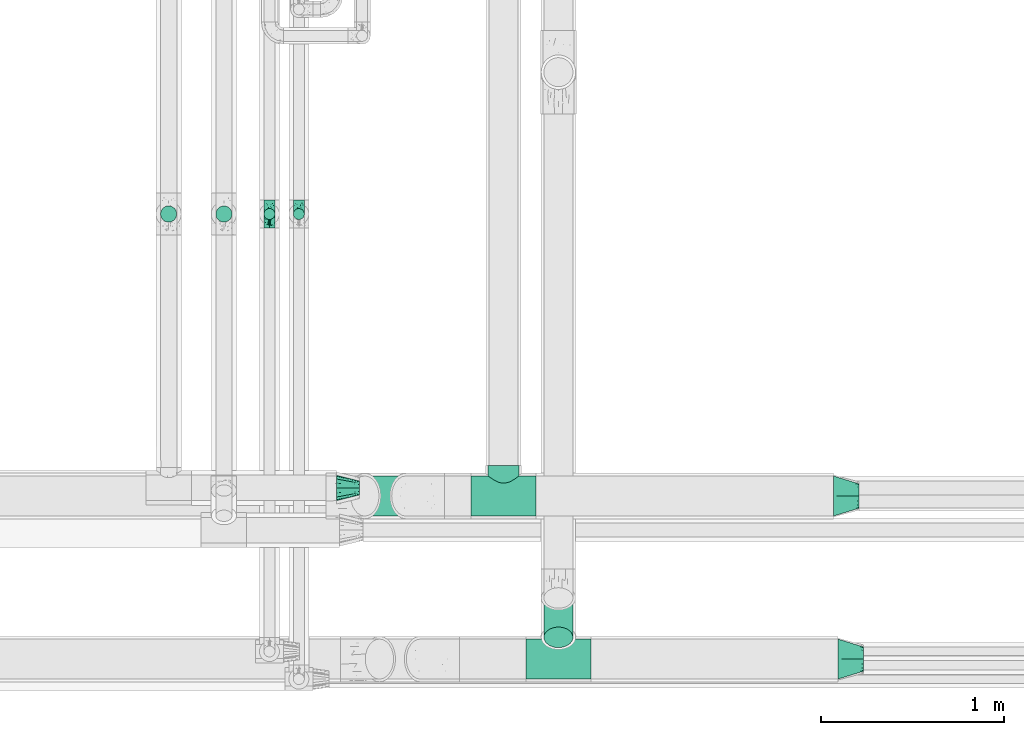
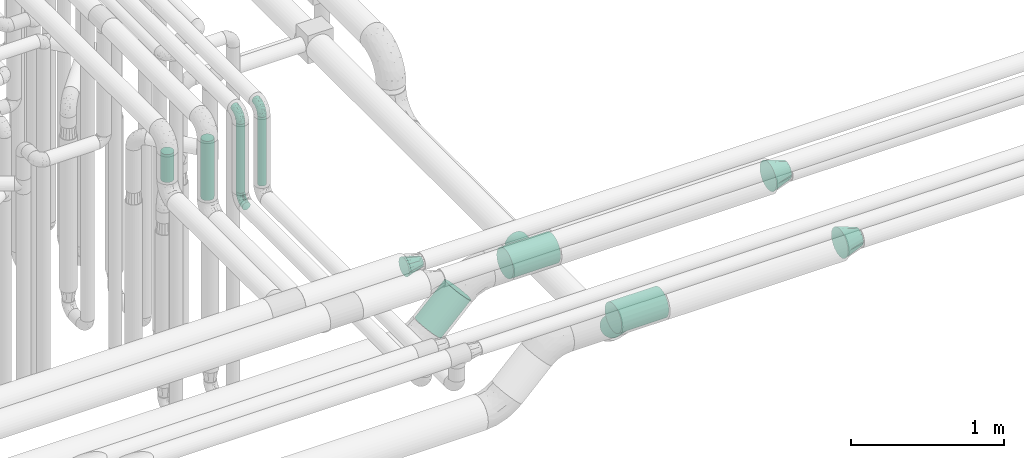
# One storey, part 605 of 827: 8 flow fittings, 6 flow segments.
"""IFC2X3 building model written with IfcOpenShell, lengths in millimetres."""

from ifc_helpers import new_model, entity, si_unit, converted_unit, derived_unit, direction, frame, origin, origin_2d_with_axis, place, context, subcontext, project, spatial, circle, extrude, faceted_brep, source, transform, mapped, material, type_object, type_shapes, element, save


model = new_model("IFC2X3")

# Units and contexts
model_context = context("Model", 3, precision=0.01, world=origin(), true_north=direction((6.12303176911189e-17, 1.0)))
body_context = subcontext(model_context, "Body", "Model", "MODEL_VIEW")
ifc_project = project(units=[si_unit("LENGTHUNIT", "METRE", prefix="MILLI"), si_unit("AREAUNIT", "SQUARE_METRE"), si_unit("VOLUMEUNIT", "CUBIC_METRE"), converted_unit("PLANEANGLEUNIT", "DEGREE", entity("IfcRatioMeasure", 0.0174532925199433), si_unit("PLANEANGLEUNIT", "RADIAN"), dimensions=[0, 0, 0, 0, 0, 0, 0]), si_unit("MASSUNIT", "GRAM", prefix="KILO"), derived_unit("MASSDENSITYUNIT", [(si_unit("MASSUNIT", "GRAM", prefix="KILO"), 1), (si_unit("LENGTHUNIT", "METRE"), -3)]), derived_unit("MOMENTOFINERTIAUNIT", [(si_unit("LENGTHUNIT", "METRE"), 4)]), si_unit("TIMEUNIT", "SECOND"), si_unit("FREQUENCYUNIT", "HERTZ"), si_unit("THERMODYNAMICTEMPERATUREUNIT", "DEGREE_CELSIUS"), derived_unit("THERMALTRANSMITTANCEUNIT", [(si_unit("MASSUNIT", "GRAM", prefix="KILO"), 1), (si_unit("THERMODYNAMICTEMPERATUREUNIT", "KELVIN"), -1), (si_unit("TIMEUNIT", "SECOND"), -3)]), derived_unit("VOLUMETRICFLOWRATEUNIT", [(si_unit("LENGTHUNIT", "METRE"), 3), (si_unit("TIMEUNIT", "SECOND"), -1)]), derived_unit("MASSFLOWRATEUNIT", [(si_unit("MASSUNIT", "GRAM", prefix="KILO"), 1), (si_unit("TIMEUNIT", "SECOND"), -1)]), derived_unit("ROTATIONALFREQUENCYUNIT", [(si_unit("TIMEUNIT", "SECOND"), -1)]), si_unit("ELECTRICCURRENTUNIT", "AMPERE"), si_unit("ELECTRICVOLTAGEUNIT", "VOLT"), si_unit("POWERUNIT", "WATT"), si_unit("FORCEUNIT", "NEWTON", prefix="KILO"), si_unit("ILLUMINANCEUNIT", "LUX"), si_unit("LUMINOUSFLUXUNIT", "LUMEN"), si_unit("LUMINOUSINTENSITYUNIT", "CANDELA"), derived_unit("USERDEFINED", [(si_unit("MASSUNIT", "GRAM", prefix="KILO"), -1), (si_unit("LENGTHUNIT", "METRE"), -2), (si_unit("TIMEUNIT", "SECOND"), 3), (si_unit("LUMINOUSFLUXUNIT", "LUMEN"), 1)]), derived_unit("LINEARVELOCITYUNIT", [(si_unit("LENGTHUNIT", "METRE"), 1), (si_unit("TIMEUNIT", "SECOND"), -1)]), si_unit("PRESSUREUNIT", "PASCAL"), derived_unit("USERDEFINED", [(si_unit("LENGTHUNIT", "METRE"), -2), (si_unit("MASSUNIT", "GRAM", prefix="KILO"), 1), (si_unit("TIMEUNIT", "SECOND"), -2)]), derived_unit("LINEARFORCEUNIT", [(si_unit("MASSUNIT", "GRAM", prefix="KILO"), 1), (si_unit("LENGTHUNIT", "METRE"), 1), (si_unit("TIMEUNIT", "SECOND"), -2), (si_unit("LENGTHUNIT", "METRE"), -1)]), derived_unit("PLANARFORCEUNIT", [(si_unit("MASSUNIT", "GRAM", prefix="KILO"), 1), (si_unit("LENGTHUNIT", "METRE"), 1), (si_unit("TIMEUNIT", "SECOND"), -2), (si_unit("LENGTHUNIT", "METRE"), -2)])], contexts=[model_context])

# Site, building, storey
site_placement = place(None, origin())
site = spatial("IfcSite", under=ifc_project, at=site_placement, CompositionType="ELEMENT")
building_placement = place(site_placement, origin())
building = spatial("IfcBuilding", under=site, at=building_placement, CompositionType="ELEMENT")
storey_placement = place(building_placement, frame((0.0, 0.0, 28200.0)))
storey = spatial("IfcBuildingStorey", under=building, at=storey_placement, Name="08", CompositionType="ELEMENT", Elevation=28200.0)

# Flow segments
pipe_segment_type_1 = type_object("IfcPipeSegmentType", PredefinedType="NOTDEFINED")
flow_segment_1_placement = place(storey_placement, frame((36911.29, 7155.11, 2508.8)))
element("IfcFlowSegment", 1, at=flow_segment_1_placement, inside=storey, type_object=pipe_segment_type_1, context=body_context, shape_type="SweptSolid", body=[
    extrude(circle(Radius=109.5, at=origin_2d_with_axis()), frame((79.02, 111.1, 79.03), z_axis=(0.707128324867819, 0.0, 0.707085236848877), x_axis=(0.0, 1.0, 0.0)), (0.0, 0.0, 1.0), 317.064992744885),
])
flow_segment_2_placement = place(storey_placement, frame((37967.2, 6435.98, 2508.09)))
element("IfcFlowSegment", 2, at=flow_segment_2_placement, inside=storey, type_object=pipe_segment_type_1, context=body_context, shape_type="SweptSolid", body=[
    extrude(circle(Radius=79.5, at=origin_2d_with_axis()), frame((81.1, 57.81, 273.12), z_axis=(0.0, 0.707106781186546, -0.707106781186549), x_axis=(1.0, 0.0, 0.0)), (0.0, 0.0, 1.0), 304.487373415324),
])
pipe_segment_type_2 = type_object("IfcPipeSegmentType", PredefinedType="NOTDEFINED")
flow_segment_3_placement = place(storey_placement, frame((36174.19, 8761.54, 2964.0)))
element("IfcFlowSegment", 3, at=flow_segment_3_placement, inside=storey, type_object=pipe_segment_type_2, context=body_context, shape_type="SweptSolid", body=[
    extrude(circle(Radius=44.25, at=origin_2d_with_axis()), frame((45.85, 45.85, 0.0), z_axis=(0.0, 0.0, 1.0), x_axis=(-1.0, 0.0, 0.0)), (0.0, 0.0, 1.0), 472.000402937329),
])
flow_segment_4_placement = place(storey_placement, frame((35872.22, 8761.54, 3214.0)))
element("IfcFlowSegment", 4, at=flow_segment_4_placement, inside=storey, type_object=pipe_segment_type_2, context=body_context, shape_type="SweptSolid", body=[
    extrude(circle(Radius=44.25, at=origin_2d_with_axis()), frame((45.85, 45.85, 0.0)), (0.0, 0.0, 1.0), 222.001032735806),
])
flow_segment_5_placement = place(storey_placement, frame((36598.05, 8775.79, 2926.0)))
element("IfcFlowSegment", 5, at=flow_segment_5_placement, inside=storey, type_object=pipe_segment_type_2, context=body_context, shape_type="SweptSolid", body=[
    extrude(circle(Radius=30.0, at=origin_2d_with_axis()), frame((31.6, 31.6, 0.0)), (0.0, 0.0, 1.0), 547.999328702734),
])
flow_segment_6_placement = place(storey_placement, frame((36437.12, 8775.79, 2926.0)))
element("IfcFlowSegment", 6, at=flow_segment_6_placement, inside=storey, type_object=pipe_segment_type_2, context=body_context, shape_type="SweptSolid", body=[
    extrude(circle(Radius=30.0, at=origin_2d_with_axis()), frame((31.6, 31.6, 0.0), z_axis=(0.0, 0.0, 1.0), x_axis=(-1.0, 0.0, 0.0)), (0.0, 0.0, 1.0), 548.000000000049),
])

# Flow fittings
ifc_material = material()
pipe_fitting_type_1 = type_object("IfcPipeFittingType", Name="ADSK_1", PredefinedType="NOTDEFINED", material=ifc_material)
shared_shape_1 = source(origin(), body_context, "Body", "Brep", [
    faceted_brep([(-76.0, 15.07, -26.11), (-76.0, 7.8, -29.12), (-76.0, 0.0, -30.15), (-76.0, -7.8, -29.12), (-76.0, -15.08, -26.11), (-76.0, -21.32, -21.32), (-76.0, -26.11, -15.08), (-76.0, -29.12, -7.8), (-76.0, -30.15, 0.0), (-76.0, -29.12, 7.8), (-76.0, -26.11, 15.07), (-76.0, -21.32, 21.32), (-76.0, -15.08, 26.11), (-76.0, -7.8, 29.12), (-76.0, 0.0, 30.15), (-76.0, 7.8, 29.12), (-76.0, 15.07, 26.11), (-76.0, 21.32, 21.32), (-76.0, 26.11, 15.07), (-76.0, 29.12, 7.8), (-76.0, 30.15, 0.0), (-76.0, 29.12, -7.8), (-76.0, 26.11, -15.08), (-76.0, 21.32, -21.32), (0.0, 76.0, -30.15), (-7.8, 76.0, -29.12), (-15.07, 76.0, -26.11), (-21.32, 76.0, -21.32), (-26.11, 76.0, -15.08), (-29.12, 76.0, -7.8), (-30.15, 76.0, 0.0), (-29.12, 76.0, 7.8), (-26.11, 76.0, 15.07), (-21.32, 76.0, 21.32), (-15.07, 76.0, 26.11), (-7.8, 76.0, 29.12), (0.0, 76.0, 30.15), (7.8, 76.0, 29.12), (15.08, 76.0, 26.11), (21.32, 76.0, 21.32), (26.11, 76.0, 15.07), (29.12, 76.0, 7.8), (30.15, 76.0, 0.0), (29.12, 76.0, -7.8), (26.11, 76.0, -15.08), (21.32, 76.0, -21.32), (15.08, 76.0, -26.11), (7.8, 76.0, -29.12), (10.79, 31.43, 21.07), (4.32, 31.7, 25.72), (1.65, 15.19, 19.92), (-61.17, -27.8, 0.0), (-51.1, -25.49, 9.84), (-56.14, -10.61, 27.27), (-31.7, -4.32, 25.72), (-39.75, 1.72, 29.41), (-43.2, -24.95, 0.0), (-1.86, 1.86, 0.0), (4.49, 7.65, 5.78), (-7.82, -4.61, 5.83), (-56.21, -22.79, 17.21), (-58.98, -3.38, 29.7), (-53.96, 5.6, 30.07), (-10.86, 10.86, 25.48), (-17.2, -2.6, 20.44), (-49.15, -16.01, 22.7), (-22.18, -14.24, 7.99), (-28.4, -17.42, 0.0), (-13.61, -9.88, 0.0), (-39.0, 23.48, 27.76), (-58.76, 12.54, 28.36), (-41.61, 15.41, 29.48), (16.01, 49.15, 22.7), (-58.55, 25.93, 19.53), (-51.53, 33.5, 13.51), (-64.92, 28.76, 12.4), (-7.48, 23.14, 28.25), (-1.72, 39.75, 29.41), (-12.04, 27.88, 29.88), (-63.91, 18.81, 24.52), (-11.63, 65.16, 28.18), (-4.97, 57.02, 30.05), (9.88, 13.61, 0.0), (-62.5, 31.74, 5.02), (-45.17, 30.98, 21.2), (-21.78, 9.76, 28.58), (10.61, 56.14, 27.27), (-32.09, 54.42, 13.26), (22.79, 56.21, 17.21), (15.38, 31.17, 15.63), (25.49, 51.1, 9.84), (21.84, 36.35, 5.92), (24.95, 43.2, 0.0), (3.38, 58.98, 29.7), (-31.17, -15.38, 15.63), (-39.39, 41.78, 15.45), (-34.56, 41.13, 20.79), (-39.81, -23.25, 5.49), (27.8, 61.17, 0.0), (-31.74, 62.5, 5.02), (-53.07, 36.29, 0.0), (-42.95, 42.95, 7.29), (-36.29, 53.07, 0.0), (-19.83, 58.51, 24.79), (-25.48, 60.2, 19.41), (-14.53, 50.96, 28.57), (-13.31, 37.09, 30.07), (-26.16, 40.06, 26.4), (-32.43, -10.35, 21.9), (17.42, 28.4, 0.0), (14.24, 22.18, 7.99), (-38.67, 9.72, 30.15), (-24.66, 17.36, 30.09), (-37.08, 31.49, 24.99), (-49.27, 22.83, 25.24), (-20.8, 38.81, 28.63), (-27.58, 27.58, 29.2), (-36.07, -20.23, 10.71), (-15.19, -6.16, 14.9), (6.6, 15.4, 14.49), (-2.51, 2.51, 11.35), (-65.16, 11.63, -28.18), (-49.15, -16.01, -22.7), (-57.02, 4.97, -30.05), (-25.93, 58.55, -19.53), (-33.5, 51.53, -13.51), (-28.76, 64.92, -12.4), (-60.2, 25.48, -19.41), (-58.51, 19.83, -24.79), (4.61, 7.82, -5.83), (-7.65, -4.49, -5.78), (-2.51, 2.51, -11.35), (-62.5, 31.74, -5.02), (-50.96, 14.53, -28.57), (-37.09, 13.31, -30.07), (-42.95, 42.95, -7.29), (25.49, 51.1, -9.84), (22.79, 56.21, -17.21), (-40.06, 26.16, -26.4), (3.38, 58.98, -29.7), (-5.6, 53.96, -30.07), (-27.88, 12.04, -29.88), (-9.76, 21.78, -28.58), (-23.14, 7.48, -28.25), (-51.1, -25.49, -9.84), (15.38, 31.17, -15.63), (16.01, 49.15, -22.7), (-23.48, 39.0, -27.76), (-12.54, 58.76, -28.36), (-15.41, 41.61, -29.48), (-56.21, -22.79, -17.21), (-9.72, 38.67, -30.15), (-17.36, 24.66, -30.09), (-22.18, -14.24, -7.99), (-41.13, 34.56, -20.79), (-31.74, 62.5, -5.02), (-58.98, -3.38, -29.7), (-31.17, -15.38, -15.63), (-56.14, -10.61, -27.27), (14.24, 22.18, -7.99), (23.25, 39.81, -5.49), (-31.49, 37.08, -24.99), (-15.19, -6.16, -14.9), (1.65, 15.19, -19.92), (-18.81, 63.91, -24.52), (-32.59, -11.62, -20.84), (-31.7, -4.32, -25.72), (-17.2, -2.6, -20.44), (-39.75, 1.72, -29.41), (-54.42, 32.09, -13.26), (-30.98, 45.17, -21.2), (10.61, 56.14, -27.27), (10.23, 31.31, -21.52), (4.32, 31.7, -25.72), (-41.78, 39.39, -15.45), (-1.72, 39.75, -29.41), (-36.35, -21.84, -5.92), (-22.83, 49.27, -25.24), (-38.81, 20.8, -28.63), (-27.58, 27.58, -29.2), (-10.86, 10.86, -25.48), (20.23, 36.07, -10.71), (6.6, 15.4, -14.49)], [[[0, 1, 2, 3, 4, 5, 6, 7, 8, 9, 10, 11, 12, 13, 14, 15, 16, 17, 18, 19, 20, 21, 22, 23]], [[24, 25, 26, 27, 28, 29, 30, 31, 32, 33, 34, 35, 36, 37, 38, 39, 40, 41, 42, 43, 44, 45, 46, 47]], [[48, 49, 50]], [[51, 52, 9]], [[53, 54, 55]], [[9, 52, 10]], [[56, 52, 51]], [[57, 58, 59]], [[11, 10, 60]], [[14, 61, 62]], [[63, 54, 64]], [[65, 12, 11]], [[65, 53, 12]], [[66, 67, 68]], [[69, 70, 71]], [[72, 39, 38]], [[73, 74, 75]], [[15, 70, 16]], [[76, 77, 78]], [[16, 79, 17]], [[13, 61, 14]], [[35, 80, 81]], [[14, 62, 15]], [[17, 73, 18]], [[57, 82, 58]], [[20, 19, 83]], [[75, 19, 18]], [[70, 15, 62]], [[73, 84, 74]], [[78, 85, 76]], [[38, 86, 72]], [[32, 31, 87]], [[88, 89, 90]], [[91, 92, 90]], [[72, 86, 49]], [[36, 93, 37]], [[75, 83, 19]], [[36, 35, 81]], [[60, 94, 65]], [[40, 90, 41]], [[95, 96, 87]], [[88, 90, 40]], [[66, 97, 67]], [[90, 98, 41]], [[40, 39, 88]], [[99, 31, 30]], [[20, 83, 100]], [[101, 102, 100]], [[52, 60, 10]], [[102, 99, 30]], [[96, 103, 104]], [[83, 101, 100]], [[12, 53, 13]], [[104, 103, 33]], [[105, 106, 81]], [[107, 105, 103]], [[64, 54, 108]], [[80, 103, 105]], [[80, 35, 34]], [[34, 33, 103]], [[86, 38, 37]], [[109, 110, 82]], [[71, 111, 112]], [[69, 107, 113]], [[79, 73, 17]], [[114, 113, 84]], [[33, 32, 104]], [[115, 107, 116]], [[105, 115, 106]], [[93, 81, 77]], [[54, 53, 65]], [[61, 53, 55]], [[108, 94, 64]], [[54, 63, 85]], [[93, 86, 37]], [[77, 76, 49]], [[77, 49, 86]], [[49, 63, 50]], [[60, 52, 117]], [[65, 11, 60]], [[39, 72, 88]], [[89, 88, 72]], [[71, 70, 62]], [[79, 70, 114]], [[103, 96, 107]], [[69, 113, 114]], [[112, 106, 116]], [[77, 81, 106]], [[112, 116, 71]], [[112, 55, 85]], [[64, 50, 63]], [[57, 59, 68]], [[32, 87, 104]], [[96, 104, 87]], [[94, 118, 64]], [[50, 119, 89]], [[50, 64, 118]], [[50, 89, 48]], [[81, 93, 36]], [[86, 93, 77]], [[53, 61, 13]], [[62, 61, 55]], [[71, 62, 111]], [[69, 71, 116]], [[95, 101, 74]], [[99, 101, 87]], [[118, 66, 59]], [[117, 97, 66]], [[117, 66, 94]], [[91, 89, 110]], [[91, 110, 109]], [[110, 89, 119]], [[9, 8, 51]], [[98, 90, 92]], [[98, 42, 41]], [[101, 83, 74]], [[101, 99, 102]], [[87, 31, 99]], [[62, 55, 111]], [[55, 112, 111]], [[107, 69, 116]], [[70, 69, 114]], [[107, 96, 113]], [[84, 113, 96]], [[84, 96, 95]], [[114, 84, 73]], [[70, 79, 16]], [[73, 79, 114]], [[54, 85, 55]], [[76, 85, 63]], [[49, 76, 63]], [[77, 106, 78]], [[106, 112, 78]], [[85, 78, 112]], [[73, 75, 18]], [[83, 75, 74]], [[103, 80, 34]], [[81, 80, 105]], [[101, 95, 87]], [[84, 95, 74]], [[106, 115, 116]], [[105, 107, 115]], [[120, 59, 58]], [[82, 110, 58]], [[119, 58, 110]], [[118, 59, 120]], [[66, 68, 59]], [[54, 65, 108]], [[94, 108, 65]], [[66, 118, 94]], [[50, 118, 120]], [[50, 120, 119]], [[119, 120, 58]], [[89, 72, 48]], [[49, 48, 72]], [[60, 117, 94]], [[117, 52, 97]], [[52, 56, 97]], [[67, 97, 56]], [[92, 91, 109]], [[89, 91, 90]], [[121, 1, 0]], [[122, 5, 4]], [[2, 1, 123]], [[124, 125, 126]], [[127, 128, 23]], [[129, 130, 131]], [[100, 132, 20]], [[133, 134, 123]], [[135, 100, 102]], [[136, 137, 44]], [[133, 128, 138]], [[24, 139, 140]], [[141, 142, 143]], [[121, 128, 133]], [[6, 144, 7]], [[137, 145, 146]], [[144, 51, 7]], [[147, 148, 149]], [[144, 6, 150]], [[149, 151, 152]], [[153, 68, 67]], [[154, 128, 127]], [[30, 155, 102]], [[43, 42, 98]], [[156, 3, 2]], [[157, 144, 150]], [[158, 4, 3]], [[24, 140, 25]], [[155, 135, 102]], [[159, 160, 109]], [[30, 29, 155]], [[147, 138, 161]], [[27, 124, 28]], [[57, 129, 82]], [[162, 163, 131]], [[27, 26, 164]], [[148, 26, 25]], [[165, 166, 167]], [[24, 47, 139]], [[143, 168, 141]], [[22, 21, 169]], [[125, 124, 170]], [[148, 25, 140]], [[46, 146, 171]], [[158, 122, 4]], [[0, 23, 128]], [[1, 121, 123]], [[109, 82, 159]], [[45, 44, 137]], [[146, 46, 45]], [[136, 43, 98]], [[132, 21, 20]], [[136, 98, 92]], [[172, 173, 146]], [[46, 171, 47]], [[43, 136, 44]], [[174, 154, 169]], [[171, 173, 175]], [[6, 5, 150]], [[126, 29, 28]], [[176, 56, 144]], [[122, 158, 166]], [[164, 124, 27]], [[177, 161, 170]], [[23, 22, 127]], [[178, 138, 179]], [[133, 178, 134]], [[156, 123, 168]], [[156, 158, 3]], [[168, 143, 166]], [[168, 166, 158]], [[166, 180, 167]], [[173, 171, 146]], [[139, 171, 175]], [[172, 145, 163]], [[173, 180, 142]], [[5, 122, 150]], [[157, 150, 122]], [[137, 136, 181]], [[146, 45, 137]], [[149, 148, 140]], [[164, 148, 177]], [[128, 154, 138]], [[147, 161, 177]], [[152, 134, 179]], [[168, 123, 134]], [[152, 179, 149]], [[152, 175, 142]], [[57, 130, 129]], [[157, 165, 167]], [[22, 169, 127]], [[154, 127, 169]], [[163, 167, 180]], [[162, 157, 167]], [[173, 163, 180]], [[182, 163, 145]], [[123, 156, 2]], [[158, 156, 168]], [[171, 139, 47]], [[140, 139, 175]], [[149, 140, 151]], [[147, 149, 179]], [[174, 135, 125]], [[132, 135, 169]], [[176, 157, 153]], [[176, 153, 67]], [[153, 157, 162]], [[182, 159, 129]], [[181, 160, 159]], [[181, 159, 145]], [[51, 144, 56]], [[51, 8, 7]], [[135, 132, 100]], [[169, 21, 132]], [[126, 155, 29]], [[135, 155, 125]], [[140, 175, 151]], [[175, 152, 151]], [[138, 147, 179]], [[148, 147, 177]], [[138, 154, 161]], [[170, 161, 154]], [[170, 154, 174]], [[177, 170, 124]], [[148, 164, 26]], [[124, 164, 177]], [[173, 142, 175]], [[143, 142, 180]], [[166, 143, 180]], [[168, 134, 141]], [[134, 152, 141]], [[142, 141, 152]], [[124, 126, 28]], [[155, 126, 125]], [[128, 121, 0]], [[123, 121, 133]], [[135, 174, 169]], [[170, 174, 125]], [[134, 178, 179]], [[133, 138, 178]], [[130, 153, 162]], [[68, 153, 130]], [[57, 68, 130]], [[182, 129, 131]], [[159, 82, 129]], [[157, 122, 165]], [[166, 165, 122]], [[163, 162, 167]], [[162, 131, 130]], [[145, 172, 146]], [[163, 173, 172]], [[159, 182, 145]], [[131, 163, 182]], [[56, 176, 67]], [[157, 176, 144]], [[137, 181, 145]], [[181, 136, 160]], [[136, 92, 160]], [[109, 160, 92]]]),
])
type_shapes(pipe_fitting_type_1, [shared_shape_1])
for number, where, z_axis, x_axis, name in (
    (7, (36468.72, 8807.39, 2850.0), (1.0, 0.0, 0.0), (0.0, 1.0, 0.0), "ADSK_1"),
    (8, (36468.72, 8807.39, 3550.0), (-1.0, 0.0, 0.0), (0.0, 0.0, 1.0), "ADSK_1"),
    (9, (36629.64, 8807.39, 3550.0), (1.0, 0.0, 0.0), (0.0, -1.0, 0.0), "ADSK_1"),
):
    element("IfcFlowFitting", number, at=place(storey_placement, frame(where, z_axis=z_axis, x_axis=x_axis)), inside=storey, type_object=pipe_fitting_type_1, material=ifc_material, Name=name, ObjectType="ADSK_1", context=body_context, shape_type="MappedRepresentation", body=[
        mapped(shared_shape_1, transform((0.0, 0.0, 0.0), scale=1.0)),
    ])
pipe_fitting_type_2 = type_object("IfcPipeFittingType", Name="ADSK_1", PredefinedType="NOTDEFINED", material=ifc_material)
shared_shape_2 = source(origin(), body_context, "Body", "Brep", [
    faceted_brep([(127.0, 32.95, 19.03), (127.0, 25.99, 25.99), (127.0, 19.02, 32.95), (127.0, 9.51, 35.5), (127.0, 0.0, 38.05), (127.0, -9.51, 35.5), (127.0, -19.03, 32.95), (127.0, -25.99, 25.99), (127.0, -32.95, 19.03), (127.0, -35.5, 9.51), (127.0, -38.05, 0.0), (127.0, -35.5, -9.51), (127.0, -32.95, -19.02), (127.0, -25.99, -25.99), (127.0, -19.03, -32.95), (127.0, -9.51, -35.5), (127.0, 0.0, -38.05), (127.0, 9.51, -35.5), (127.0, 19.02, -32.95), (127.0, 25.99, -25.99), (127.0, 32.95, -19.02), (127.0, 35.5, -9.51), (127.0, 38.05, 0.0), (127.0, 35.5, 9.51), (0.0, 38.06, 56.96), (0.0, 49.39, 49.39), (0.0, 56.96, 38.06), (0.0, 64.53, 26.73), (0.0, 67.19, 13.37), (0.0, 69.85, 0.0), (0.0, 67.19, -13.37), (0.0, 64.53, -26.73), (0.0, 56.96, -38.06), (0.0, 49.39, -49.39), (0.0, 38.06, -56.96), (0.0, 26.73, -64.53), (0.0, 13.37, -67.19), (0.0, 0.0, -69.85), (0.0, -13.37, -67.19), (0.0, -26.73, -64.53), (0.0, -38.06, -56.96), (0.0, -49.39, -49.39), (0.0, -56.96, -38.06), (0.0, -64.53, -26.73), (0.0, -67.19, -13.37), (0.0, -69.85, 0.0), (0.0, -67.19, 13.37), (0.0, -64.53, 26.73), (0.0, -56.96, 38.06), (0.0, -49.39, 49.39), (0.0, -38.06, 56.96), (0.0, -26.73, 64.53), (0.0, -13.37, 67.19), (0.0, 0.0, 69.85), (0.0, 13.37, 67.19), (0.0, 26.73, 64.53)], [[[0, 1, 2, 3, 4, 5, 6, 7, 8, 9, 10, 11, 12, 13, 14, 15, 16, 17, 18, 19, 20, 21, 22, 23]], [[24, 25, 26, 27, 28, 29, 30, 31, 32, 33, 34, 35, 36, 37, 38, 39, 40, 41, 42, 43, 44, 45, 46, 47, 48, 49, 50, 51, 52, 53, 54, 55]], [[30, 29, 22]], [[16, 15, 38]], [[18, 35, 34]], [[15, 39, 38]], [[13, 12, 42]], [[13, 40, 14]], [[16, 36, 17]], [[40, 13, 41]], [[35, 18, 17]], [[21, 31, 30]], [[19, 32, 20]], [[19, 18, 34]], [[19, 34, 33]], [[40, 39, 14]], [[15, 14, 39]], [[38, 37, 16]], [[21, 20, 31]], [[12, 43, 42]], [[44, 10, 45]], [[32, 19, 33]], [[22, 21, 30]], [[10, 44, 11]], [[42, 41, 13]], [[32, 31, 20]], [[36, 35, 17]], [[43, 12, 11]], [[44, 43, 11]], [[36, 16, 37]], [[46, 45, 10]], [[4, 3, 54]], [[6, 51, 50]], [[3, 55, 54]], [[1, 0, 26]], [[1, 24, 2]], [[4, 52, 5]], [[24, 1, 25]], [[51, 6, 5]], [[9, 47, 46]], [[7, 48, 8]], [[7, 6, 50]], [[7, 50, 49]], [[24, 55, 2]], [[3, 2, 55]], [[54, 53, 4]], [[9, 8, 47]], [[0, 27, 26]], [[28, 22, 29]], [[48, 7, 49]], [[10, 9, 46]], [[22, 28, 23]], [[26, 25, 1]], [[48, 47, 8]], [[52, 51, 5]], [[27, 0, 23]], [[28, 27, 23]], [[52, 4, 53]]]),
])
type_shapes(pipe_fitting_type_2, [shared_shape_2])
flow_fitting_placement = place(storey_placement, frame((36835.03, 7310.0, 3100.0)))
element("IfcFlowFitting", 10, at=flow_fitting_placement, inside=storey, type_object=pipe_fitting_type_2, material=ifc_material, Name="ADSK_1", ObjectType="ADSK_1", context=body_context, shape_type="MappedRepresentation", body=[
    mapped(shared_shape_2, transform((0.0, 0.0, 0.0), scale=1.0)),
])
pipe_fitting_type_3 = type_object("IfcPipeFittingType", Name="ADSK_1", PredefinedType="NOTDEFINED", material=ifc_material)
shared_shape_3 = source(origin(), body_context, "Body", "Brep", [
    faceted_brep([(-178.0, 0.0, -109.55), (-178.0, -28.35, -105.82), (-178.0, -54.78, -94.87), (-178.0, -77.46, -77.46), (-178.0, -86.17, -66.12), (-178.0, -94.87, -54.78), (-178.0, -100.35, -41.56), (-178.0, -105.82, -28.35), (-178.0, -107.68, -14.18), (-178.0, -109.55, 0.0), (-178.0, -107.68, 14.18), (-178.0, -105.82, 28.35), (-178.0, -100.35, 41.56), (-178.0, -94.87, 54.77), (-178.0, -86.17, 66.12), (-178.0, -77.46, 77.46), (-178.0, -54.78, 94.87), (-178.0, -28.35, 105.82), (-178.0, 0.0, 109.55), (-178.0, 28.35, 105.82), (-178.0, 54.77, 94.87), (-178.0, 77.46, 77.46), (-178.0, 94.87, 54.77), (-178.0, 105.82, 28.35), (-178.0, 109.55, 0.0), (-178.0, 105.82, -28.35), (-178.0, 94.87, -54.78), (-178.0, 77.46, -77.46), (-178.0, 54.77, -94.87), (-178.0, 28.35, -105.82), (178.0, 0.0, -109.55), (178.0, 28.35, -105.82), (178.0, 54.77, -94.87), (178.0, 77.46, -77.46), (178.0, 94.87, -54.78), (178.0, 105.82, -28.35), (178.0, 109.55, 0.0), (178.0, 105.82, 28.35), (178.0, 94.87, 54.77), (178.0, 77.46, 77.46), (178.0, 54.77, 94.87), (178.0, 28.35, 105.82), (178.0, 0.0, 109.55), (178.0, -28.35, 105.82), (178.0, -54.78, 94.87), (178.0, -77.46, 77.46), (178.0, -86.17, 66.12), (178.0, -94.87, 54.77), (178.0, -100.35, 41.56), (178.0, -105.82, 28.35), (178.0, -107.68, 14.18), (178.0, -109.55, 0.0), (178.0, -107.68, -14.18), (178.0, -105.82, -28.35), (178.0, -100.35, -41.56), (178.0, -94.87, -54.78), (178.0, -86.17, -66.12), (178.0, -77.46, -77.46), (178.0, -54.78, -94.87), (178.0, -28.35, -105.82), (82.88, -108.58, 14.54), (84.15, -109.55, 0.0), (-84.15, -109.55, 0.0), (79.21, -105.8, 28.42), (73.4, -101.53, 41.15), (65.81, -96.18, 52.45), (56.69, -90.19, 62.19), (46.22, -84.0, 70.32), (34.46, -78.15, 76.77), (-79.21, -105.8, 28.42), (-73.4, -101.53, 41.15), (-82.88, -108.58, 14.54), (-46.22, -84.0, 70.32), (-34.46, -78.15, 76.77), (-56.69, -90.19, 62.19), (-65.8, -96.18, 52.45), (-21.44, -73.35, 81.37), (21.44, -73.35, 81.37), (7.31, -70.52, 83.83), (-7.31, -70.52, 83.83), (21.44, -73.35, -81.37), (7.31, -70.52, -83.83), (-82.88, -108.58, -14.54), (-73.4, -101.53, -41.15), (-7.31, -70.52, -83.83), (-21.44, -73.35, -81.37), (-34.46, -78.15, -76.77), (-56.69, -90.19, -62.19), (56.69, -90.19, -62.19), (46.22, -84.0, -70.32), (65.81, -96.18, -52.45), (34.46, -78.15, -76.77), (82.88, -108.58, -14.54), (79.21, -105.8, -28.42), (73.4, -101.53, -41.15), (-46.22, -84.0, -70.32), (-65.8, -96.18, -52.45), (-79.21, -105.8, -28.42), (0.0, -168.0, -84.15), (21.78, -168.0, -81.28), (42.08, -168.0, -72.88), (59.5, -168.0, -59.5), (72.88, -168.0, -42.08), (81.28, -168.0, -21.78), (84.15, -168.0, 0.0), (81.28, -168.0, 21.78), (72.88, -168.0, 42.07), (59.5, -168.0, 59.5), (42.08, -168.0, 72.88), (21.78, -168.0, 81.28), (0.0, -168.0, 84.15), (-21.78, -168.0, 81.28), (-42.07, -168.0, 72.88), (-59.5, -168.0, 59.5), (-72.88, -168.0, 42.07), (-81.28, -168.0, 21.78), (-84.15, -168.0, 0.0), (-81.28, -168.0, -21.78), (-72.88, -168.0, -42.08), (-59.5, -168.0, -59.5), (-42.07, -168.0, -72.88), (-21.78, -168.0, -81.28)], [[[0, 1, 2, 3, 4, 5, 6, 7, 8, 9, 10, 11, 12, 13, 14, 15, 16, 17, 18, 19, 20, 21, 22, 23, 24, 25, 26, 27, 28, 29]], [[30, 31, 32, 33, 34, 35, 36, 37, 38, 39, 40, 41, 42, 43, 44, 45, 46, 47, 48, 49, 50, 51, 52, 53, 54, 55, 56, 57, 58, 59]], [[50, 49, 60]], [[61, 51, 50]], [[62, 10, 9]], [[63, 60, 49]], [[49, 64, 63]], [[48, 65, 64]], [[65, 48, 47]], [[65, 47, 66]], [[67, 66, 46]], [[45, 68, 67]], [[67, 46, 45]], [[64, 49, 48]], [[69, 70, 11]], [[71, 69, 11]], [[10, 62, 71]], [[70, 12, 11]], [[72, 73, 15]], [[72, 15, 14]], [[74, 13, 75]], [[13, 74, 14]], [[13, 12, 75]], [[15, 73, 76]], [[66, 47, 46]], [[61, 50, 60]], [[17, 16, 44, 43]], [[77, 45, 78]], [[44, 78, 45]], [[71, 11, 10]], [[18, 17, 43, 42]], [[22, 21, 39, 38]], [[23, 22, 38, 37]], [[20, 19, 41, 40]], [[21, 20, 40, 39]], [[41, 19, 18, 42]], [[24, 23, 37, 36]], [[75, 12, 70]], [[72, 14, 74]], [[79, 78, 16]], [[79, 16, 15]], [[44, 16, 78]], [[79, 15, 76]], [[77, 68, 45]], [[33, 27, 26, 34]], [[35, 25, 24, 36]], [[35, 34, 26, 25]], [[28, 27, 33, 32]], [[59, 1, 0, 30]], [[58, 2, 1, 59]], [[31, 30, 0, 29]], [[80, 81, 57]], [[62, 8, 82]], [[32, 31, 29, 28]], [[81, 58, 57]], [[81, 2, 58]], [[83, 7, 6]], [[3, 84, 85]], [[2, 84, 3]], [[3, 85, 86]], [[84, 2, 81]], [[87, 5, 4]], [[56, 55, 88]], [[89, 57, 56]], [[90, 88, 55]], [[54, 90, 55]], [[57, 89, 91]], [[52, 51, 61]], [[8, 62, 9]], [[52, 61, 92]], [[93, 94, 53]], [[92, 93, 53]], [[53, 94, 54]], [[90, 54, 94]], [[92, 53, 52]], [[4, 95, 87]], [[89, 56, 88]], [[87, 96, 5]], [[96, 83, 6]], [[3, 95, 4]], [[95, 3, 86]], [[97, 82, 7]], [[83, 97, 7]], [[82, 8, 7]], [[6, 5, 96]], [[91, 80, 57]], [[98, 99, 100, 101, 102, 103, 104, 105, 106, 107, 108, 109, 110, 111, 112, 113, 114, 115, 116, 117, 118, 119, 120, 121]], [[116, 115, 71]], [[71, 62, 116]], [[71, 115, 69]], [[113, 112, 74]], [[75, 114, 113]], [[69, 115, 114]], [[73, 112, 111]], [[70, 69, 114]], [[75, 113, 74]], [[114, 75, 70]], [[72, 112, 73]], [[76, 73, 111]], [[74, 112, 72]], [[79, 76, 111]], [[111, 110, 79]], [[108, 68, 109]], [[109, 78, 110]], [[66, 108, 107]], [[60, 105, 104]], [[107, 106, 65]], [[105, 63, 106]], [[104, 61, 60]], [[77, 109, 68]], [[78, 109, 77]], [[108, 67, 68]], [[60, 63, 105]], [[67, 108, 66]], [[66, 107, 65]], [[63, 64, 106]], [[106, 64, 65]], [[110, 78, 79]], [[104, 103, 92]], [[92, 61, 104]], [[92, 103, 93]], [[90, 102, 101]], [[101, 100, 88]], [[93, 103, 102]], [[91, 100, 99]], [[94, 93, 102]], [[90, 101, 88]], [[102, 90, 94]], [[89, 100, 91]], [[80, 91, 99]], [[88, 100, 89]], [[81, 80, 99]], [[99, 98, 81]], [[120, 86, 121]], [[121, 84, 98]], [[87, 120, 119]], [[82, 117, 116]], [[119, 118, 96]], [[117, 97, 118]], [[116, 62, 82]], [[85, 121, 86]], [[84, 121, 85]], [[120, 95, 86]], [[82, 97, 117]], [[95, 120, 87]], [[87, 119, 96]], [[97, 83, 118]], [[118, 83, 96]], [[98, 84, 81]]]),
])
type_shapes(pipe_fitting_type_3, [shared_shape_3])
for number, where, z_axis, x_axis, name in (
    (11, (37748.3, 7266.2, 2899.91), (2.63361265065324e-05, 0.0, 1.0), (-1.0, 0.0, 2.63361265065324e-05), "ADSK_1"),
    (12, (38048.3, 6375.0, 2900.0), (0.0, 0.707106781186546, 0.707106781186549), (-1.0, 0.0, 0.0), "ADSK_1"),
):
    element("IfcFlowFitting", number, at=place(storey_placement, frame(where, z_axis=z_axis, x_axis=x_axis)), inside=storey, type_object=pipe_fitting_type_3, material=ifc_material, Name=name, ObjectType="ADSK_1", context=body_context, shape_type="MappedRepresentation", body=[
        mapped(shared_shape_3, transform((0.0, 0.0, 0.0), scale=1.0)),
    ])
pipe_fitting_type_4 = type_object("IfcPipeFittingType", Name="ADSK_2", PredefinedType="NOTDEFINED", material=ifc_material)
shared_shape_4 = source(origin(), body_context, "Body", "Brep", [
    faceted_brep([(140.0, 104.14, -33.84), (140.0, 109.5, 0.0), (140.0, 104.14, 33.84), (140.0, 88.59, 64.36), (140.0, 64.36, 88.59), (140.0, 33.84, 104.14), (140.0, 0.0, 109.5), (140.0, -33.84, 104.14), (140.0, -64.36, 88.59), (140.0, -88.59, 64.36), (140.0, -104.14, 33.84), (140.0, -109.5, 0.0), (140.0, -104.14, -33.84), (140.0, -88.59, -64.36), (140.0, -64.36, -88.59), (140.0, -33.84, -104.14), (140.0, 0.0, -109.5), (140.0, 33.84, -104.14), (140.0, 64.36, -88.59), (140.0, 88.59, -64.36), (0.0, 66.5, 0.0), (0.0, 63.97, -12.72), (0.0, 61.44, -25.45), (0.0, 54.23, -36.24), (0.0, 47.02, -47.02), (0.0, 36.24, -54.23), (0.0, 25.45, -61.44), (0.0, 12.72, -63.97), (0.0, 0.0, -66.5), (0.0, -12.72, -63.97), (0.0, -25.45, -61.44), (0.0, -36.24, -54.23), (0.0, -47.02, -47.02), (0.0, -54.23, -36.24), (0.0, -61.44, -25.45), (0.0, -63.97, -12.72), (0.0, -66.5, 0.0), (0.0, -63.97, 12.72), (0.0, -61.44, 25.45), (0.0, -54.23, 36.24), (0.0, -47.02, 47.02), (0.0, -36.24, 54.23), (0.0, -25.45, 61.44), (0.0, -12.72, 63.97), (0.0, 0.0, 66.5), (0.0, 12.72, 63.97), (0.0, 25.45, 61.44), (0.0, 36.24, 54.23), (0.0, 47.02, 47.02), (0.0, 54.23, 36.24), (0.0, 61.44, 25.45), (0.0, 63.97, 12.72)], [[[0, 1, 2, 3, 4, 5, 6, 7, 8, 9, 10, 11, 12, 13, 14, 15, 16, 17, 18, 19]], [[20, 21, 22, 23, 24, 25, 26, 27, 28, 29, 30, 31, 32, 33, 34, 35, 36, 37, 38, 39, 40, 41, 42, 43, 44, 45, 46, 47, 48, 49, 50, 51]], [[11, 35, 12]], [[34, 13, 12]], [[27, 16, 28]], [[14, 32, 31, 30]], [[13, 34, 33, 32]], [[28, 16, 29]], [[35, 34, 12]], [[14, 13, 32]], [[14, 30, 15]], [[35, 11, 36]], [[15, 30, 29]], [[27, 26, 17]], [[15, 29, 16]], [[19, 24, 23, 22]], [[16, 27, 17]], [[26, 18, 17]], [[18, 26, 25, 24]], [[20, 1, 21]], [[0, 22, 21]], [[19, 18, 24]], [[0, 19, 22]], [[0, 21, 1]], [[1, 51, 2]], [[50, 3, 2]], [[43, 6, 44]], [[4, 48, 47, 46]], [[3, 50, 49, 48]], [[44, 6, 45]], [[51, 50, 2]], [[4, 3, 48]], [[4, 46, 5]], [[51, 1, 20]], [[5, 46, 45]], [[43, 42, 7]], [[5, 45, 6]], [[9, 40, 39, 38]], [[6, 43, 7]], [[42, 8, 7]], [[8, 42, 41, 40]], [[36, 11, 37]], [[10, 38, 37]], [[9, 8, 40]], [[10, 9, 38]], [[10, 37, 11]]]),
])
type_shapes(pipe_fitting_type_4, [shared_shape_4])
for number, where, z_axis, x_axis, name in (
    (13, (39715.11, 6375.0, 2900.0), (0.0, 0.0, 1.0), (-1.0, 0.0, 0.0), "ADSK_2"),
    (14, (39691.04, 7266.2, 2899.78), (-4.2748192942016e-06, 0.0, 1.0), (-1.0, 0.0, -4.2748192942016e-06), "ADSK_2"),
):
    element("IfcFlowFitting", number, at=place(storey_placement, frame(where, z_axis=z_axis, x_axis=x_axis)), inside=storey, type_object=pipe_fitting_type_4, material=ifc_material, Name=name, ObjectType="ADSK_2", context=body_context, shape_type="MappedRepresentation", body=[
        mapped(shared_shape_4, transform((0.0, 0.0, 0.0), scale=1.0)),
    ])

save(model, "model.ifc")
